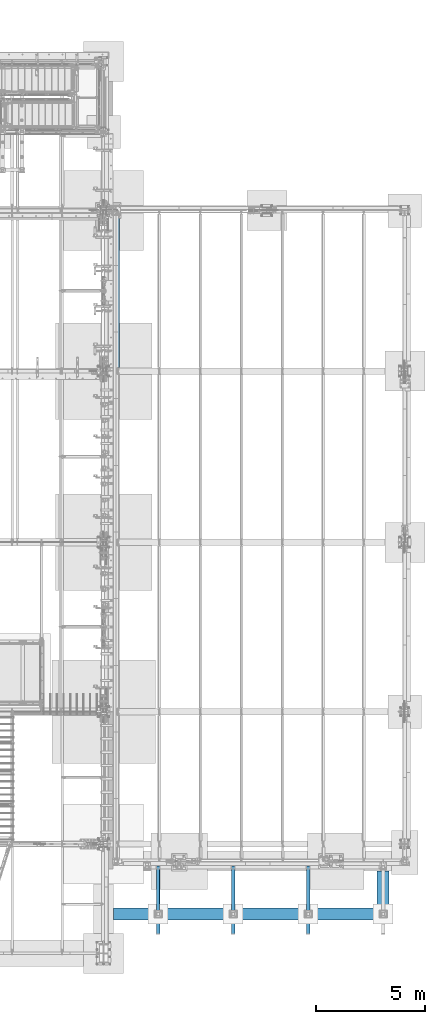
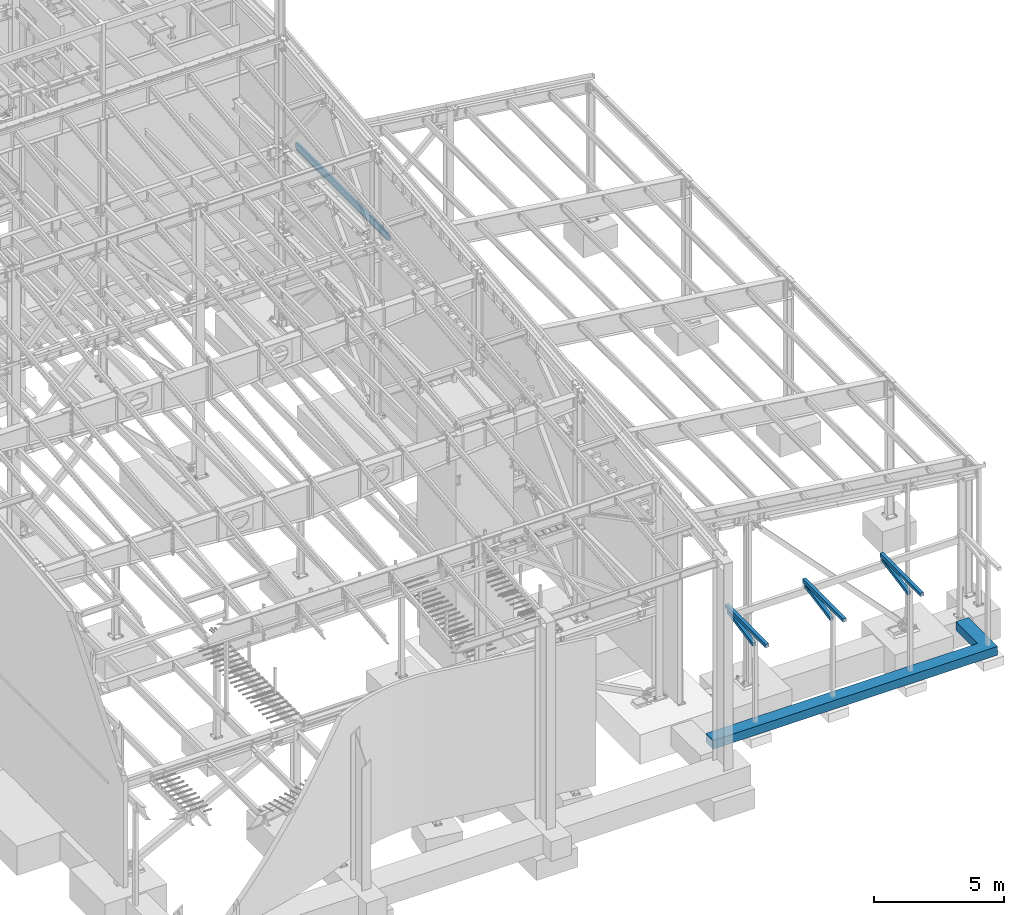
# One storey, part 743 of 1179: 8 beams, 8 elements without a shape of their own.
"""IFC2X3 building model written with IfcOpenShell, lengths in millimetres."""

from ifc_helpers import new_model, si_unit, frame, origin_with_axes, place, context, subcontext, project, spatial, faceted_brep, material, type_object, element, aggregate, save


model = new_model("IFC2X3")

# Units and contexts
model_context = context("Model", 3, precision=1e-05, world=origin_with_axes())
body_context = subcontext(model_context, "Body", "Model", "MODEL_VIEW")
ifc_project = project(units=[si_unit("LENGTHUNIT", "METRE", prefix="MILLI"), si_unit("AREAUNIT", "SQUARE_METRE"), si_unit("VOLUMEUNIT", "CUBIC_METRE"), si_unit("MASSUNIT", "GRAM", prefix="KILO"), si_unit("TIMEUNIT", "SECOND"), si_unit("PLANEANGLEUNIT", "RADIAN"), si_unit("SOLIDANGLEUNIT", "STERADIAN"), si_unit("THERMODYNAMICTEMPERATUREUNIT", "DEGREE_CELSIUS"), si_unit("LUMINOUSINTENSITYUNIT", "LUMEN")], contexts=[model_context])

# Site, building, storey
site_placement = place(None, origin_with_axes())
site = spatial("IfcSite", under=ifc_project, at=site_placement, CompositionType="ELEMENT")
building_placement = place(site_placement, origin_with_axes())
building = spatial("IfcBuilding", under=site, at=building_placement, Name="Undefined", CompositionType="ELEMENT")
storey_placement = place(building_placement, origin_with_axes())
storey = spatial("IfcBuildingStorey", under=building, at=storey_placement, Name="Undefined", CompositionType="ELEMENT", Elevation=0.0)

# Assembly, beam
assembly_1_placement = place(storey_placement, origin_with_axes())
assembly_1 = element("IfcElementAssembly", 1, at=assembly_1_placement, inside=storey, Name="V_BRACE", AssemblyPlace="NOTDEFINED", PredefinedType="RIGID_FRAME")
ifc_material_1 = material()
beam_type_1 = type_object("IfcBeamType", Name="HSS6X6X1/4", PredefinedType="NOTDEFINED")
beam_1_placement = place(assembly_1_placement, frame((33654.6667960694, 2067.11201111417, 3123.86195697912), z_axis=(-1.0, 0.0, 0.0), x_axis=(0.0, 0.982315302335757, 0.187234203063997)))
beam_1 = element("IfcBeam", 2, at=beam_1_placement, type_object=beam_type_1, material=ifc_material_1, Name="V_BRACE", ObjectType="HSS6X6X1/4", context=body_context, shape_type="Brep", body=[
    faceted_brep([(235.372165385215, 69.8500000000513, -69.8499999999985), (261.999683154555, -69.8499999999422, -69.8499999999985), (2278.86737857677, -69.8499999995015, -69.8499999999985), (2252.23986080743, 69.8500000004919, -69.8499999999985), (261.999683154555, -69.8499999999422, 69.8499999999985), (2278.86737857677, -69.8499999995015, 69.8499999999985), (235.372165385215, 69.8500000000513, 69.8499999999985), (2252.23986080743, 69.8500000004919, 69.8499999999985), (234.161823668427, 76.2000000000507, -76.1999999999971), (234.161823668427, 76.2000000000507, 76.1999999999971), (2251.02951909064, 76.2000000004919, 76.1999999999971), (2251.02951909064, 76.2000000004919, -76.1999999999971), (263.210024871343, -76.1999999999421, 76.1999999999971), (2280.07772029356, -76.199999999501, 76.1999999999971), (263.210024871343, -76.1999999999421, -76.1999999999971), (2280.07772029356, -76.199999999501, -76.1999999999971)], [[[0, 1, 2, 3]], [[1, 4, 5, 2]], [[4, 6, 7, 5]], [[6, 0, 3, 7]], [[8, 9, 10, 11]], [[9, 12, 13, 10]], [[12, 14, 15, 13]], [[14, 8, 11, 15]], [[13, 15, 11, 10], [5, 7, 3, 2]], [[14, 12, 9, 8], [6, 4, 1, 0]]]),
])
aggregate(assembly_1, [beam_1])

assembly_2_placement = place(storey_placement, origin_with_axes())
assembly_2 = element("IfcElementAssembly", 3, at=assembly_2_placement, inside=storey, Name="V_BRACE", AssemblyPlace="NOTDEFINED", PredefinedType="RIGID_FRAME")
beam_2_placement = place(assembly_2_placement, frame((30225.6667960694, 2067.11201111417, 3123.86195697912), z_axis=(-1.0, 0.0, 0.0), x_axis=(0.0, 0.982315302335757, 0.187234203063997)))
beam_2 = element("IfcBeam", 4, at=beam_2_placement, type_object=beam_type_1, material=ifc_material_1, Name="V_BRACE", ObjectType="HSS6X6X1/4", context=body_context, shape_type="Brep", body=[
    faceted_brep([(235.372165385215, 69.8500000000513, -69.8499999999985), (261.999683154555, -69.8499999999422, -69.8499999999985), (2278.86737857677, -69.8499999995015, -69.8499999999985), (2252.23986080743, 69.8500000004919, -69.8499999999985), (261.999683154555, -69.8499999999422, 69.8499999999985), (2278.86737857677, -69.8499999995015, 69.8499999999985), (235.372165385215, 69.8500000000513, 69.8499999999985), (2252.23986080743, 69.8500000004919, 69.8499999999985), (234.161823668427, 76.2000000000507, -76.1999999999971), (234.161823668427, 76.2000000000507, 76.1999999999971), (2251.02951909064, 76.2000000004919, 76.1999999999971), (2251.02951909064, 76.2000000004919, -76.1999999999971), (263.210024871343, -76.1999999999421, 76.1999999999971), (2280.07772029356, -76.199999999501, 76.1999999999971), (263.210024871343, -76.1999999999421, -76.1999999999971), (2280.07772029356, -76.199999999501, -76.1999999999971)], [[[0, 1, 2, 3]], [[1, 4, 5, 2]], [[4, 6, 7, 5]], [[6, 0, 3, 7]], [[8, 9, 10, 11]], [[9, 12, 13, 10]], [[12, 14, 15, 13]], [[14, 8, 11, 15]], [[13, 15, 11, 10], [5, 7, 3, 2]], [[14, 12, 9, 8], [6, 4, 1, 0]]]),
])
aggregate(assembly_2, [beam_2])

assembly_3_placement = place(storey_placement, origin_with_axes())
assembly_3 = element("IfcElementAssembly", 5, at=assembly_3_placement, inside=storey, Name="BEAM", AssemblyPlace="NOTDEFINED", PredefinedType="RIGID_FRAME")
beam_3_placement = place(assembly_3_placement, frame((33655.0, 1320.8, 3702.05), z_axis=(-1.0, 0.0, 0.0), x_axis=(0.0, 1.0, 0.0)))
beam_3 = element("IfcBeam", 6, at=beam_3_placement, type_object=beam_type_1, material=ifc_material_1, Name="BEAM", ObjectType="HSS6X6X1/4", context=body_context, shape_type="Brep", body=[
    faceted_brep([(6.34999999999945, 69.8500000000004, -69.8500000000004), (6.34999999999945, -69.8500000000004, -69.8500000000004), (3117.85, -69.8499999999999, -69.8499999999985), (3117.85, 69.8499999999999, -69.8499999999985), (6.34999999999945, -69.8500000000004, 69.8500000000004), (3117.85, -69.8499999999999, 69.8499999999985), (6.34999999999945, 69.8500000000004, 69.8500000000004), (3117.85, 69.8499999999999, 69.8499999999985), (6.34999999999945, 76.1999999999998, -76.2000000000007), (6.34999999999945, 76.1999999999998, 76.2000000000007), (3117.85, 76.1999999999998, 76.1999999999971), (3117.85, 76.1999999999998, -76.1999999999971), (6.34999999999945, -76.1999999999998, 76.2000000000007), (3117.85, -76.1999999999998, 76.1999999999971), (6.34999999999945, -76.1999999999998, -76.2000000000007), (3117.85, -76.1999999999998, -76.1999999999971)], [[[0, 1, 2, 3]], [[1, 4, 5, 2]], [[4, 6, 7, 5]], [[6, 0, 3, 7]], [[8, 9, 10, 11]], [[9, 12, 13, 10]], [[12, 14, 15, 13]], [[14, 8, 11, 15]], [[13, 15, 11, 10], [5, 7, 3, 2]], [[14, 12, 9, 8], [6, 4, 1, 0]]]),
])
aggregate(assembly_3, [beam_3])

assembly_4_placement = place(storey_placement, origin_with_axes())
assembly_4 = element("IfcElementAssembly", 7, at=assembly_4_placement, inside=storey, Name="BEAM", AssemblyPlace="NOTDEFINED", PredefinedType="RIGID_FRAME")
beam_4_placement = place(assembly_4_placement, frame((30226.0, 1320.8, 3702.05), z_axis=(-1.0, 0.0, 0.0), x_axis=(0.0, 1.0, 0.0)))
beam_4 = element("IfcBeam", 8, at=beam_4_placement, type_object=beam_type_1, material=ifc_material_1, Name="BEAM", ObjectType="HSS6X6X1/4", context=body_context, shape_type="Brep", body=[
    faceted_brep([(6.34999999999945, 69.8500000000004, -69.8500000000004), (6.34999999999945, -69.8500000000004, -69.8500000000004), (3117.85, -69.8499999999999, -69.8499999999985), (3117.85, 69.8499999999999, -69.8499999999985), (6.34999999999945, -69.8500000000004, 69.8500000000004), (3117.85, -69.8499999999999, 69.8499999999985), (6.34999999999945, 69.8500000000004, 69.8500000000004), (3117.85, 69.8499999999999, 69.8499999999985), (6.34999999999945, 76.1999999999998, -76.2000000000007), (6.34999999999945, 76.1999999999998, 76.2000000000007), (3117.85, 76.1999999999998, 76.1999999999971), (3117.85, 76.1999999999998, -76.1999999999971), (6.34999999999945, -76.1999999999998, 76.2000000000007), (3117.85, -76.1999999999998, 76.1999999999971), (6.34999999999945, -76.1999999999998, -76.2000000000007), (3117.85, -76.1999999999998, -76.1999999999971)], [[[0, 1, 2, 3]], [[1, 4, 5, 2]], [[4, 6, 7, 5]], [[6, 0, 3, 7]], [[8, 9, 10, 11]], [[9, 12, 13, 10]], [[12, 14, 15, 13]], [[14, 8, 11, 15]], [[13, 15, 11, 10], [5, 7, 3, 2]], [[14, 12, 9, 8], [6, 4, 1, 0]]]),
])
aggregate(assembly_4, [beam_4])

assembly_5_placement = place(storey_placement, origin_with_axes())
assembly_5 = element("IfcElementAssembly", 9, at=assembly_5_placement, inside=storey, Name="V_BRACE", AssemblyPlace="NOTDEFINED", PredefinedType="RIGID_FRAME")
beam_5_placement = place(assembly_5_placement, frame((26796.6667960694, 2067.11201111417, 3123.86195697912), z_axis=(-1.0, 0.0, 0.0), x_axis=(0.0, 0.982315302335757, 0.187234203063997)))
beam_5 = element("IfcBeam", 10, at=beam_5_placement, type_object=beam_type_1, material=ifc_material_1, Name="V_BRACE", ObjectType="HSS6X6X1/4", context=body_context, shape_type="Brep", body=[
    faceted_brep([(235.372165385215, 69.8500000000513, -69.8499999999985), (261.999683154555, -69.8499999999422, -69.8499999999985), (2278.86737857677, -69.8499999995015, -69.8499999999985), (2252.23986080743, 69.8500000004919, -69.8499999999985), (261.999683154555, -69.8499999999422, 69.8499999999985), (2278.86737857677, -69.8499999995015, 69.8499999999985), (235.372165385215, 69.8500000000513, 69.8499999999985), (2252.23986080743, 69.8500000004919, 69.8499999999985), (234.161823668427, 76.2000000000507, -76.1999999999971), (234.161823668427, 76.2000000000507, 76.1999999999971), (2251.02951909064, 76.2000000004919, 76.1999999999971), (2251.02951909064, 76.2000000004919, -76.1999999999971), (263.210024871343, -76.1999999999421, 76.1999999999971), (2280.07772029356, -76.199999999501, 76.1999999999971), (263.210024871343, -76.1999999999421, -76.1999999999971), (2280.07772029356, -76.199999999501, -76.1999999999971)], [[[0, 1, 2, 3]], [[1, 4, 5, 2]], [[4, 6, 7, 5]], [[6, 0, 3, 7]], [[8, 9, 10, 11]], [[9, 12, 13, 10]], [[12, 14, 15, 13]], [[14, 8, 11, 15]], [[13, 15, 11, 10], [5, 7, 3, 2]], [[14, 12, 9, 8], [6, 4, 1, 0]]]),
])
aggregate(assembly_5, [beam_5])

assembly_6_placement = place(storey_placement, origin_with_axes())
assembly_6 = element("IfcElementAssembly", 11, at=assembly_6_placement, inside=storey, Name="BEAM", AssemblyPlace="NOTDEFINED", PredefinedType="RIGID_FRAME")
beam_6_placement = place(assembly_6_placement, frame((26797.0, 1320.8, 3702.05), z_axis=(-1.0, 0.0, 0.0), x_axis=(0.0, 1.0, 0.0)))
beam_6 = element("IfcBeam", 12, at=beam_6_placement, type_object=beam_type_1, material=ifc_material_1, Name="BEAM", ObjectType="HSS6X6X1/4", context=body_context, shape_type="Brep", body=[
    faceted_brep([(6.34999999999945, 69.8500000000004, -69.8500000000004), (6.34999999999945, -69.8500000000004, -69.8500000000004), (3117.85, -69.8499999999999, -69.8499999999985), (3117.85, 69.8499999999999, -69.8499999999985), (6.34999999999945, -69.8500000000004, 69.8500000000004), (3117.85, -69.8499999999999, 69.8499999999985), (6.34999999999945, 69.8500000000004, 69.8500000000004), (3117.85, 69.8499999999999, 69.8499999999985), (6.34999999999945, 76.1999999999998, -76.2000000000007), (6.34999999999945, 76.1999999999998, 76.2000000000007), (3117.85, 76.1999999999998, 76.1999999999971), (3117.85, 76.1999999999998, -76.1999999999971), (6.34999999999945, -76.1999999999998, 76.2000000000007), (3117.85, -76.1999999999998, 76.1999999999971), (6.34999999999945, -76.1999999999998, -76.2000000000007), (3117.85, -76.1999999999998, -76.1999999999971)], [[[0, 1, 2, 3]], [[1, 4, 5, 2]], [[4, 6, 7, 5]], [[6, 0, 3, 7]], [[8, 9, 10, 11]], [[9, 12, 13, 10]], [[12, 14, 15, 13]], [[14, 8, 11, 15]], [[13, 15, 11, 10], [5, 7, 3, 2]], [[14, 12, 9, 8], [6, 4, 1, 0]]]),
])
aggregate(assembly_6, [beam_6])

assembly_7_placement = place(storey_placement, origin_with_axes())
assembly_7 = element("IfcElementAssembly", 13, at=assembly_7_placement, inside=storey, Name="BEAM", AssemblyPlace="NOTDEFINED", PredefinedType="RIGID_FRAME")
ifc_material_2 = material(Name="STEEL/A992")
beam_type_2 = type_object("IfcBeamType", Name="W12X22", PredefinedType="NOTDEFINED")
beam_7_placement = place(assembly_7_placement, frame((24972.7820076832, 27051.0, 7789.858358221), z_axis=(0.133813223953133, 0.0, 0.991006569652931), x_axis=(0.0, 1.0, 0.0)))
beam_7 = element("IfcBeam", 14, at=beam_7_placement, type_object=beam_type_2, material=ifc_material_2, Name="BEAM", ObjectType="W12X22", context=body_context, shape_type="Brep", body=[
    faceted_brep([(7192.96250000001, -3.1749999998392, -144.462500000049), (7192.96250000001, -50.7999999998501, -144.46250000006), (7192.96250000001, -50.7999999998356, -155.575000000066), (7192.96250000001, 50.8000000001848, -155.575000000037), (7192.96250000001, 50.8000000001775, -144.462500000034), (7192.96250000001, 3.17500000016298, -144.462500000047), (7192.96250000001, 3.17500000015571, -136.524999802685), (7192.96250000001, -3.17499999984648, -136.524999802681), (7193.9292299226, 3.17500000014843, -131.664920284635), (7193.9292299226, -3.17499999985375, -131.664920284631), (7196.68224382308, 3.17500000014115, -127.544743816477), (7196.68224382308, -3.17499999985739, -127.544743816472), (7200.80242029123, 3.17500000014115, -124.791729915994), (7200.80242029123, -3.17499999986103, -124.791729915993), (7205.66249980928, 3.17500000014115, -123.824999993407), (7205.66249980928, -3.17499999986103, -123.824999993401), (7319.96250000001, -3.17499999986103, -123.824999993298), (7319.96250000001, 3.17500000013752, -123.82499999329), (161.925000000007, 3.17499999983556, 144.462500000051), (161.925000000007, 50.7999999998428, 144.462500000063), (7192.96250000001, 50.7999999998356, 144.462500000063), (7192.96250000001, 3.17499999982465, 144.462500000052), (161.925000000007, -3.17499999984284, -136.524999799629), (161.925000000007, 3.17500000016298, -136.524999799632), (161.925000000007, 3.17500000017026, -144.462500000049), (161.925000000007, 50.8000000001775, -144.462500000034), (161.925000000007, 50.8000000001994, -155.575000000039), (161.925000000007, -50.7999999998283, -155.575000000066), (161.925000000007, -50.7999999998428, -144.462500000063), (161.925000000007, -3.17499999982101, -144.462500000049), (160.958270077419, -3.17499999984284, -131.664920281577), (160.958270077419, 3.17500000015571, -131.664920281581), (158.205256176941, -3.17499999984284, -127.54474381342), (158.205256176941, 3.17500000014843, -127.544743813425), (154.085079708788, -3.17499999985012, -124.791729912939), (154.085079708788, 3.17500000015571, -124.791729912944), (149.225000190741, -3.17499999985012, -123.824999990349), (149.225000190741, 3.17500000014115, -123.824999990355), (20.6375000000044, -3.17499999985739, -123.824999990466), (20.6375000000044, 3.17500000014843, -123.824999990458), (20.6375000000044, -3.17500000014115, 117.475000009781), (20.6375000000044, 3.17499999986467, 117.475000009788), (149.225000190741, -3.17500000014115, 117.475000009897), (149.225000190741, 3.17499999986467, 117.475000009894), (154.085079708788, -3.17500000014115, 118.441729932485), (154.085079708788, 3.17499999986467, 118.441729932481), (158.205256176941, -3.17500000014843, 121.194743832966), (158.205256176941, 3.17499999985739, 121.194743832963), (160.958270077419, -3.17500000014843, 125.314920301123), (160.958270077419, 3.17499999985739, 125.31492030112), (161.925000000007, -3.17500000014843, 130.174999819174), (161.925000000007, 3.17499999985012, 130.17499981917), (161.925000000007, -50.8000000001994, 155.575000000041), (161.925000000007, 50.7999999998356, 155.575000000066), (161.925000000007, -3.17500000017026, 144.462500000049), (161.925000000007, -50.8000000001775, 144.462500000034), (7192.96250000001, -3.17500000017753, 144.462500000049), (7192.96250000001, -50.8000000001921, 144.462500000038), (7192.96250000001, -50.8000000001994, 155.575000000041), (7192.96250000001, 50.799999999821, 155.57500000007), (7192.96250000001, -3.17500000016298, 130.174999815979), (7192.96250000001, 3.1749999998392, 130.174999815976), (7193.9292299226, -3.17500000015207, 125.314920297929), (7193.9292299226, 3.17499999984648, 125.314920297926), (7196.68224382308, -3.17500000014843, 121.194743829772), (7196.68224382308, 3.17499999985375, 121.194743829768), (7200.80242029123, -3.17500000014479, 118.441729929291), (7200.80242029123, 3.17499999985375, 118.441729929287), (7205.66249980928, -3.17500000014843, 117.475000006702), (7205.66249980928, 3.17499999985375, 117.4750000067), (7319.96250000001, -3.17500000014843, 117.475000006809), (7319.96250000001, 3.17499999985375, 117.475000006812)], [[[0, 1, 2, 3, 4, 5, 6, 7]], [[7, 6, 8, 9]], [[9, 8, 10, 11]], [[11, 10, 12, 13]], [[13, 12, 14, 15]], [[16, 15, 14, 17]], [[18, 19, 20, 21]], [[22, 23, 24, 25, 26, 27, 28, 29]], [[30, 31, 23, 22]], [[32, 33, 31, 30]], [[34, 35, 33, 32]], [[36, 37, 35, 34]], [[38, 39, 37, 36]], [[40, 41, 39, 38]], [[42, 43, 41, 40]], [[44, 45, 43, 42]], [[46, 47, 45, 44]], [[48, 49, 47, 46]], [[50, 51, 49, 48]], [[52, 53, 19, 18, 51, 50, 54, 55]], [[55, 54, 56, 57]], [[52, 55, 57, 58]], [[53, 52, 58, 59]], [[19, 53, 59, 20]], [[58, 57, 56, 60, 61, 21, 20, 59]], [[62, 63, 61, 60]], [[64, 65, 63, 62]], [[66, 67, 65, 64]], [[68, 69, 67, 66]], [[70, 71, 69, 68]], [[71, 70, 16, 17]], [[12, 10, 8, 6, 5, 24, 23, 31, 33, 35, 37, 39, 41, 43, 45, 47, 49, 51, 18, 21, 61, 63, 65, 67, 69, 71, 17, 14]], [[25, 24, 5, 4]], [[26, 25, 4, 3]], [[27, 26, 3, 2]], [[28, 27, 2, 1]], [[29, 28, 1, 0]], [[70, 68, 66, 64, 62, 60, 56, 54, 50, 48, 46, 44, 42, 40, 38, 36, 34, 32, 30, 22, 29, 0, 7, 9, 11, 13, 15, 16]]]),
])
aggregate(assembly_7, [beam_7])

assembly_8_placement = place(storey_placement, origin_with_axes())
assembly_8 = element("IfcElementAssembly", 15, at=assembly_8_placement, inside=storey, Name="GRADE_BEAM", AssemblyPlace="NOTDEFINED", PredefinedType="REINFORCEMENT_UNIT")
ifc_material_3 = material(Name="CONCRETE/5000")
beam_type_3 = type_object("IfcBeamType", PredefinedType="NOTDEFINED")
beam_8_placement = place(assembly_8_placement, frame((24765.0, 2235.2, -609.6), z_axis=(0.0, 0.0, 1.0), x_axis=(1.0, 0.0, 0.0)))
beam_8 = element("IfcBeam", 16, at=beam_8_placement, type_object=beam_type_3, material=ifc_material_3, Name="GRADE_BEAM", context=body_context, shape_type="Brep", body=[
    faceted_brep([(0.0, -279.4, -203.2), (0.0, -279.4, 203.2), (0.0, 279.4, 203.2), (0.0, 279.4, -203.2), (12039.6, 279.4, 203.2), (12039.6, 279.4, -203.2), (12598.4, -279.4, -203.2), (12598.4, -279.4, 203.2), (12039.6, 1955.80004882812, 203.2), (12039.6, 1955.80004882812, -203.2), (12598.4, 1955.80004882812, 203.2), (12598.4, 1955.80004882812, -203.2)], [[[0, 1, 2, 3]], [[3, 2, 4, 5]], [[1, 0, 6, 7]], [[5, 4, 8, 9]], [[4, 2, 1, 7, 10, 8]], [[7, 6, 11, 10]], [[6, 0, 3, 5, 9, 11]], [[10, 11, 9, 8]]]),
])
aggregate(assembly_8, [beam_8])

save(model, "model.ifc")
